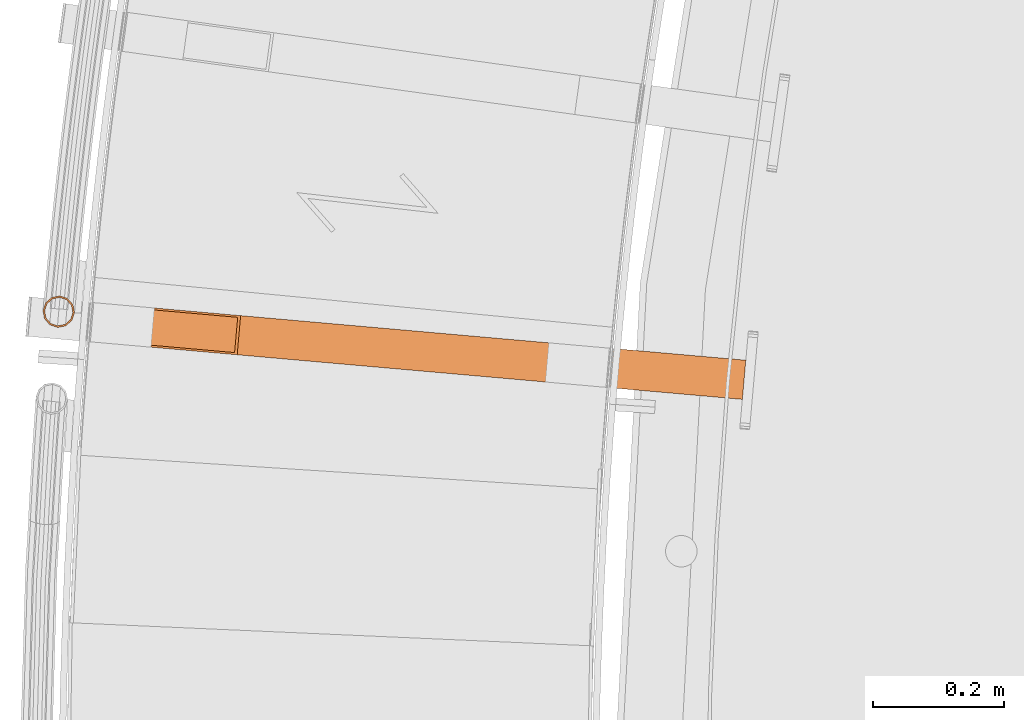
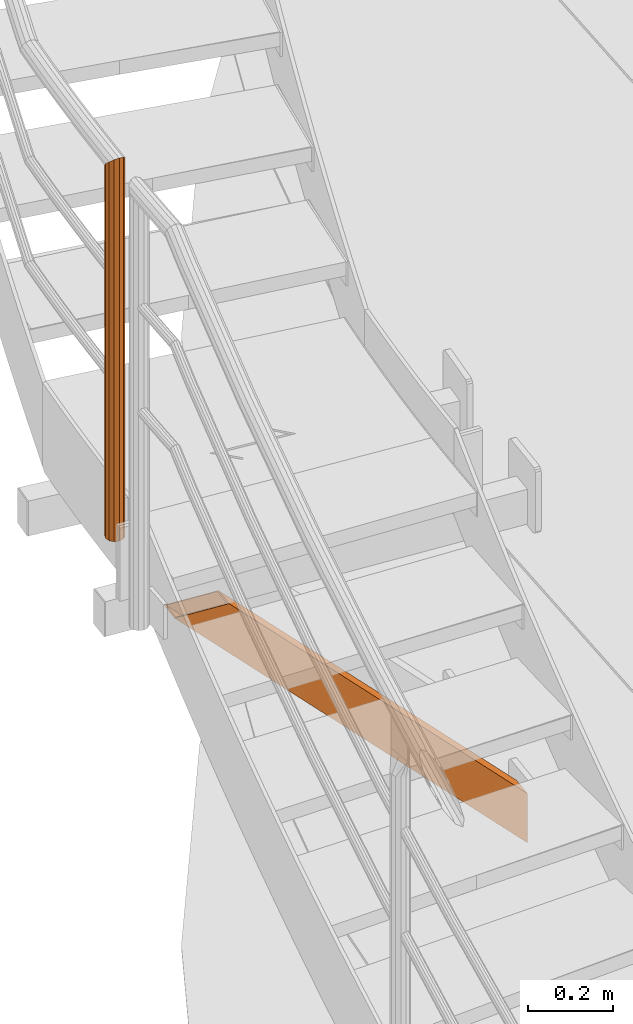
# One storey, part 24 of 126: 2 proxies.
"""IFC2X3 building model written with IfcOpenShell, lengths in millimetres."""

from ifc_helpers import new_model, si_unit, origin, origin_with_axes, place, context, project, spatial, faceted_brep, material, element, save


model = new_model("IFC2X3")

# Units and contexts
context_of_model_1 = context(None, 3, precision=0.1, world=origin())
context_of_model_2 = context(None, 3, precision=0.1, world=origin())
ifc_project = project(units=[si_unit("LENGTHUNIT", "METRE", prefix="MILLI"), si_unit("AREAUNIT", "SQUARE_METRE", prefix="CENTI"), si_unit("VOLUMEUNIT", "CUBIC_METRE", prefix="CENTI"), si_unit("MASSUNIT", "GRAM", prefix="KILO")], contexts=[context_of_model_1, context_of_model_2])

# Site, building, storey
site_placement = place(None, origin_with_axes())
site = spatial("IfcSite", under=ifc_project, at=site_placement, CompositionType="ELEMENT")
building_placement = place(site_placement, origin_with_axes())
building = spatial("IfcBuilding", under=site, at=building_placement, CompositionType="ELEMENT")
storey_placement = place(building_placement, origin_with_axes())
storey = spatial("IfcBuildingStorey", under=building, at=storey_placement, CompositionType="ELEMENT")

# Proxies
ifc_material = material(Name="S235JRG2")
proxy_1_placement = place(storey_placement, origin_with_axes())
element("IfcBuildingElementProxy", 1, at=proxy_1_placement, inside=storey, material=ifc_material, context=context_of_model_2, shape_type="Brep", body=[
    faceted_brep([(-692.2072, 8742.6739, 5292.55), (-686.9309, 8802.4414, 5292.55), (224.9062, 8721.9443, 4377.1666), (219.63, 8662.1768, 4377.1666), (-546.0575, 8790.0051, 5292.55), (224.9062, 8721.9443, 4518.5879), (-551.3337, 8730.2376, 5292.55), (219.63, 8662.1768, 4518.5879), (-687.7172, 8745.2892, 5292.55), (-555.2961, 8733.599, 5292.55), (219.8938, 8665.1652, 4514.3453), (219.8938, 8665.1652, 4381.4092), (-550.5475, 8787.3898, 5292.55), (224.6424, 8718.956, 4514.3453), (-682.9685, 8799.08, 5292.55), (224.6424, 8718.956, 4381.4092)], [[[0, 1, 2, 3]], [[1, 4, 5, 2]], [[4, 6, 7, 5]], [[0, 3, 7, 6]], [[8, 9, 10, 11]], [[9, 12, 13, 10]], [[12, 14, 15, 13]], [[8, 11, 15, 14]], [[1, 0, 6, 4], [8, 14, 12, 9]], [[3, 2, 5, 7], [10, 13, 15, 11]]]),
])
proxy_2_placement = place(storey_placement, origin_with_axes())
element("IfcBuildingElementProxy", 2, at=proxy_2_placement, inside=storey, material=ifc_material, Name="HANDLAUF", context=context_of_model_2, shape_type="Brep", body=[
    faceted_brep([(-822.0655, 8820.14, 6594.25), (-810.2259, 8816.1279, 6597.4855), (-810.2259, 8816.1279, 5542.55), (-822.0655, 8820.14, 5542.55), (-801.9785, 8806.7335, 6606.325), (-801.9785, 8806.7335, 5542.55), (-799.5333, 8794.474, 6618.4), (-799.5333, 8794.474, 5542.55), (-803.5454, 8782.6344, 6630.475), (-803.5454, 8782.6344, 5542.55), (-812.9398, 8774.387, 6639.3145), (-812.9398, 8774.387, 5542.55), (-825.1993, 8771.9418, 6642.55), (-825.1993, 8771.9418, 5542.55), (-837.0389, 8775.9539, 6639.3145), (-837.0389, 8775.9539, 5542.55), (-845.2863, 8785.3483, 6630.475), (-845.2863, 8785.3483, 5542.55), (-847.7315, 8797.6077, 6618.4), (-847.7315, 8797.6077, 5542.55), (-843.7194, 8809.4474, 6606.325), (-843.7194, 8809.4474, 5542.55), (-834.325, 8817.6948, 6597.4855), (-834.325, 8817.6948, 5542.55), (-822.2278, 8817.6453, 6596.75), (-833.2181, 8815.4531, 6599.6506), (-833.2181, 8815.4531, 5542.55), (-822.2278, 8817.6453, 5542.55), (-841.64, 8808.0595, 6607.575), (-841.64, 8808.0595, 5542.55), (-845.2368, 8797.4455, 6618.4), (-845.2368, 8797.4455, 5542.55), (-843.0447, 8786.4552, 6629.225), (-843.0447, 8786.4552, 5542.55), (-835.6511, 8778.0333, 6637.1495), (-835.6511, 8778.0333, 5542.55), (-825.0371, 8774.4365, 6640.05), (-825.0371, 8774.4365, 5542.55), (-814.0467, 8776.6286, 6637.1495), (-814.0467, 8776.6286, 5542.55), (-805.6248, 8784.0222, 6629.225), (-805.6248, 8784.0222, 5542.55), (-802.028, 8794.6362, 6618.4), (-802.028, 8794.6362, 5542.55), (-804.2201, 8805.6266, 6607.575), (-804.2201, 8805.6266, 5542.55), (-811.6137, 8814.0485, 6599.6506), (-811.6137, 8814.0485, 5542.55)], [[[0, 1, 2, 3]], [[1, 4, 5, 2]], [[4, 6, 7, 5]], [[6, 8, 9, 7]], [[8, 10, 11, 9]], [[10, 12, 13, 11]], [[12, 14, 15, 13]], [[14, 16, 17, 15]], [[16, 18, 19, 17]], [[18, 20, 21, 19]], [[20, 22, 23, 21]], [[0, 3, 23, 22]], [[24, 25, 26, 27]], [[25, 28, 29, 26]], [[28, 30, 31, 29]], [[30, 32, 33, 31]], [[32, 34, 35, 33]], [[34, 36, 37, 35]], [[36, 38, 39, 37]], [[38, 40, 41, 39]], [[40, 42, 43, 41]], [[42, 44, 45, 43]], [[44, 46, 47, 45]], [[24, 27, 47, 46]], [[18, 16, 14, 12, 10, 8, 6, 4, 1, 0, 22, 20], [24, 46, 44, 42, 40, 38, 36, 34, 32, 30, 28, 25]], [[19, 21, 23, 3, 2, 5, 7, 9, 11, 13, 15, 17], [26, 29, 31, 33, 35, 37, 39, 41, 43, 45, 47, 27]]]),
])

save(model, "model.ifc")
